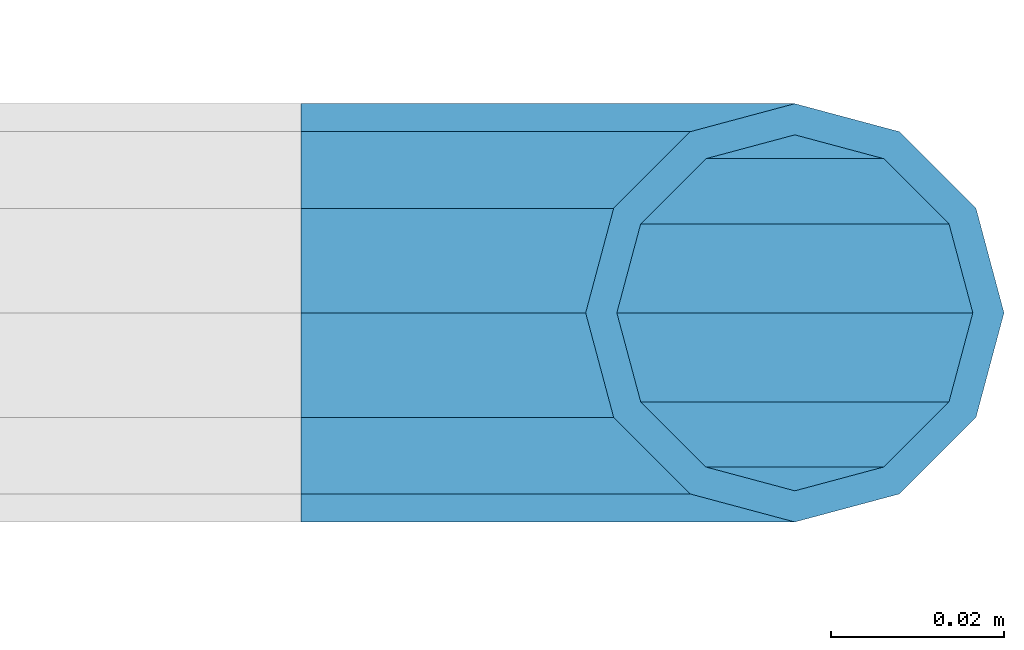
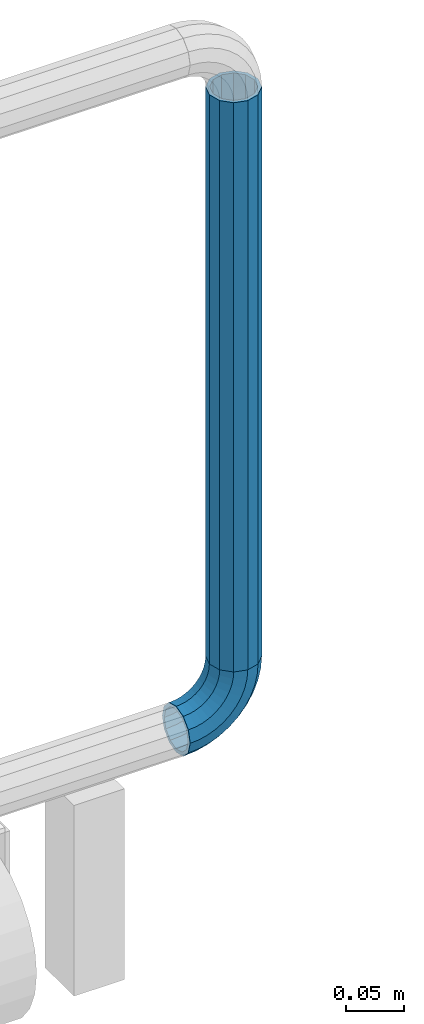
# One storey, part 151 of 208: 1 beam, 1 member.
"""IFC2X3 building model written with IfcOpenShell, lengths in millimetres."""

from ifc_helpers import new_model, si_unit, frame, origin_with_axes, place, context, subcontext, project, spatial, faceted_brep, material, type_object, element, save


model = new_model("IFC2X3")

# Units and contexts
model_context = context("Model", 3, precision=1e-05, world=origin_with_axes())
body_context = subcontext(model_context, "Body", "Model", "MODEL_VIEW")
ifc_project = project(units=[si_unit("LENGTHUNIT", "METRE", prefix="MILLI"), si_unit("AREAUNIT", "SQUARE_METRE"), si_unit("VOLUMEUNIT", "CUBIC_METRE"), si_unit("MASSUNIT", "GRAM", prefix="KILO"), si_unit("TIMEUNIT", "SECOND"), si_unit("PLANEANGLEUNIT", "RADIAN"), si_unit("SOLIDANGLEUNIT", "STERADIAN"), si_unit("THERMODYNAMICTEMPERATUREUNIT", "DEGREE_CELSIUS"), si_unit("LUMINOUSINTENSITYUNIT", "LUMEN")], contexts=[model_context])

# Site, building, storey
site_placement = place(None, origin_with_axes())
site = spatial("IfcSite", under=ifc_project, at=site_placement, CompositionType="ELEMENT")
building_placement = place(site_placement, origin_with_axes())
building = spatial("IfcBuilding", under=site, at=building_placement, Name="Standard", CompositionType="ELEMENT")
storey_placement = place(building_placement, origin_with_axes())
storey = spatial("IfcBuildingStorey", under=building, at=storey_placement, Name="Undefined", CompositionType="ELEMENT", Elevation=0.0)

# Member
ifc_material = material()
member_type = type_object("IfcMemberType", PredefinedType="NOTDEFINED")
member_placement = place(storey_placement, frame((-12120.0539827644, 5941.85399999618, 281.650006544463), z_axis=(0.0, -1.0, 0.0), x_axis=(-0.707106781186548, 0.0, -0.707106781186548)))
element("IfcMember", 1, at=member_placement, inside=storey, type_object=member_type, material=ifc_material, context=body_context, shape_type="Brep", body=[
    faceted_brep([(17.0766287656552, -17.0766287656552, 0.0), (14.7887943220539, -14.7887943220539, -12.0749999999998), (19.0945697419538, -11.1113146999724, -12.0749999999998), (20.9963409898282, -13.7288782624146, 0.0), (8.53831438282759, -8.53831438282759, -20.9145135013941), (13.8988340683954, -3.95999805533756, -20.9145135013941), (0.0, 0.0, -24.1500000000001), (6.80132714696265, 5.80888215173945, -24.1500000000001), (-8.53831438282759, 8.53831438282759, -20.9145135013941), (-0.296179774470147, 15.5777623588165, -20.9145135013941), (-14.7887943220521, 14.7887943220521, -12.0749999999998), (-5.49191544802852, 22.7290790034513, -12.0749999999998), (-17.0766287656552, 17.0766287656552, 0.0), (-7.39368669589931, 25.3466425658935, 0.0), (-14.7887943220521, 14.7887943220521, 12.0749999999998), (-5.49191544802852, 22.7290790034513, 12.0749999999998), (-8.53831438282759, 8.53831438282759, 20.9145135013941), (-0.296179774470147, 15.5777623588165, 20.9145135013941), (0.0, 0.0, 24.1500000000001), (6.80132714696265, 5.80888215173945, 24.1500000000001), (8.53831438282759, -8.53831438282759, 20.9145135013941), (13.8988340683954, -3.95999805533756, 20.9145135013941), (14.7887943220539, -14.7887943220539, 12.0749999999998), (19.0945697419538, -11.1113146999724, 12.0749999999998), (14.5310443533836, -14.5310443533836, 0.0), (12.5842535535485, -12.5842535535485, 10.2750000000001), (17.2620366843166, -8.58904933077247, 10.2750000000001), (18.8803140815726, -10.8164170826676, 0.0), (7.26552217669268, -7.26552217669268, 17.7968220477701), (12.8408206142685, -2.50376746546499, 17.7968220477701), (0.0, 0.0, 20.5500000000002), (6.80132714696265, 5.80888215173945, 20.5500000000002), (-7.26552217669087, 7.26552217669087, 17.7968220477701), (0.761833679658594, 14.1215317689421, 17.7968220477701), (-12.5842535535485, 12.5842535535485, 10.2750000000001), (-3.65938239039133, 20.2068136342514, 10.2750000000001), (-14.5310443533836, 14.5310443533836, 0.0), (-5.27765978764546, 22.4341813861447, 0.0), (-12.5842535535485, 12.5842535535485, -10.2750000000001), (-3.65938239039133, 20.2068136342514, -10.2750000000001), (-7.26552217669087, 7.26552217669087, -17.7968220477701), (0.761833679658594, 14.1215317689421, -17.7968220477701), (0.0, 0.0, -20.5500000000002), (6.80132714696265, 5.80888215173945, -20.5500000000002), (7.26552217669268, -7.26552217669268, -17.7968220477701), (12.8408206142685, -2.50376746546499, -17.7968220477701), (12.5842535535485, -12.5842535535485, -10.2750000000001), (17.2620366843166, -8.58904933077247, -10.2750000000001), (23.9226184787876, -8.15268262886457, -12.0749999999998), (25.3914986111904, -11.0355222080452, 0.0), (19.9095633268353, -0.27661842847192, -20.9145135013941), (14.4276280424801, 10.482285351105, -24.1500000000001), (8.94569275812501, 21.2411891306783, -20.9145135013941), (4.93263760617265, 29.117253331071, -12.0749999999998), (3.46375747377169, 32.0000929102534, 0.0), (4.93263760617265, 29.117253331071, 12.0749999999998), (8.94569275812501, 21.2411891306783, 20.9145135013941), (14.4276280424801, 10.482285351105, 24.1500000000001), (19.9095633268353, -0.27661842847192, 20.9145135013941), (23.9226184787876, -8.15268262886457, 12.0749999999998), (22.5072161777225, -5.3747992032786, 10.2750000000001), (23.7571328121267, -7.82789872096691, 0.0), (19.0923804273043, 1.32719331506814, 17.7968220477701), (14.4276280424801, 10.482285351105, 20.5500000000002), (9.76287565765597, 19.6373773871383, 17.7968220477701), (6.34803990723776, 26.3393699054886, 10.2750000000001), (5.0981232728318, 28.7924694231751, 0.0), (6.34803990723776, 26.3393699054886, -10.2750000000001), (9.76287565765597, 19.6373773871383, -17.7968220477701), (14.4276280424801, 10.482285351105, -20.5500000000002), (19.0923804273043, 1.32719331506814, -17.7968220477701), (22.5072161777225, -5.3747992032786, -10.2750000000001), (29.1540579492776, -5.98574944945176, -12.0749999999998), (30.1538782624175, -9.06287996733772, 0.0), (26.422498055339, 2.42112746692692, -20.9145135013941), (22.6911178482624, 13.9051349011897, -24.1500000000001), (18.9597376411857, 25.3891423354562, -20.9145135013941), (16.2281777472472, 33.7960192518349, -12.0749999999998), (15.2283574341091, 36.873149769719, 0.0), (16.2281777472472, 33.7960192518349, 12.0749999999998), (18.9597376411857, 25.3891423354562, 20.9145135013941), (22.6911178482624, 13.9051349011897, 24.1500000000001), (26.422498055339, 2.42112746692692, 20.9145135013941), (29.1540579492776, -5.98574944945176, 12.0749999999998), (28.1906383068908, -3.0206486766856, 10.2750000000001), (29.041417082668, -5.63907650867441, 0.0), (25.8662674654661, 4.13302919625858, 17.7968220477701), (22.6911178482624, 13.9051349011897, 20.5500000000002), (19.5159682310605, 23.6772406061227, 17.7968220477701), (17.1915973896339, 30.8309184790687, 10.2750000000001), (16.3408186138568, 33.4493463110575, 0.0), (17.1915973896339, 30.8309184790687, -10.2750000000001), (19.5159682310605, 23.6772406061227, -17.7968220477701), (22.6911178482624, 13.9051349011897, -20.5500000000002), (25.8662674654661, 4.13302919625858, -17.7968220477701), (28.1906383068908, -3.0206486766856, -10.2750000000001), (34.660072751507, -4.66387224825667, -12.0749999999998), (35.1662143510621, -7.85952453908249, 0.0), (33.2772681857005, 4.06681217360347, -20.9145135013941), (31.3883220203406, 15.9931488862876, -24.1500000000001), (29.4993758549808, 27.9194855989754, -20.9145135013941), (28.1165712891743, 36.6501700208355, -12.0749999999998), (27.6104296896192, 39.8458223116613, 0.0), (28.1165712891743, 36.6501700208355, 12.0749999999998), (29.4993758549808, 27.9194855989754, 20.9145135013941), (31.3883220203406, 15.9931488862876, 24.1500000000001), (33.2772681857005, 4.06681217360347, 20.9145135013941), (34.660072751507, -4.66387224825667, 12.0749999999998), (34.1723583568, -1.58456474993909, 10.2750000000001), (34.6030502769172, -4.30384651293934, 0.0), (32.995686148628, 5.84465118667504, 17.7968220477701), (31.3883220203406, 15.9931488862876, 20.5500000000002), (29.7809578920533, 26.1416465859038, 17.7968220477701), (28.6042856838831, 33.5708625225197, 10.2750000000001), (28.1735937637659, 36.29014428552, 0.0), (28.6042856838831, 33.5708625225197, -10.2750000000001), (29.7809578920533, 26.1416465859038, -17.7968220477701), (31.3883220203406, 15.9931488862876, -20.5500000000002), (32.995686148628, 5.84465118667504, -17.7968220477701), (34.1723583568, -1.58456474993909, -10.2750000000001), (40.3050865276346, -4.21960002902779, -12.0749999999998), (40.3050865276346, -7.45508652763237, 0.0), (40.3050865276327, 4.61991347236653, -20.9145135013941), (40.3050865276327, 16.6949134723673, -24.1500000000001), (40.3050865276346, 28.7699134723662, -20.9145135013941), (40.3050865276346, 37.6094269737623, -12.0749999999998), (40.3050865276346, 40.8449134723669, 0.0), (40.3050865276346, 37.6094269737623, 12.0749999999998), (40.3050865276346, 28.7699134723662, 20.9145135013941), (40.3050865276327, 16.6949134723673, 24.1500000000001), (40.3050865276327, 4.61991347236653, 20.9145135013941), (40.3050865276346, -4.21960002902779, 12.0749999999998), (40.3050865276327, -1.10190857540329, 10.2750000000001), (40.3050865276346, -3.85508652763383, 0.0), (40.3050865276346, 6.41991347236763, 17.7968220477701), (40.3050865276327, 16.6949134723673, 20.5500000000002), (40.3050865276346, 26.9699134723669, 17.7968220477701), (40.3050865276346, 34.491735520136, 10.2750000000001), (40.3050865276327, 37.2449134723665, 0.0), (40.3050865276346, 34.491735520136, -10.2750000000001), (40.3050865276346, 26.9699134723669, -17.7968220477701), (40.3050865276327, 16.6949134723673, -20.5500000000002), (40.3050865276346, 6.41991347236763, -17.7968220477701), (40.3050865276327, -1.10190857540329, -10.2750000000001), (45.9501003037603, -4.66387224825485, -12.0749999999998), (45.4439587042052, -7.8595245390843, 0.0), (47.3329048695668, 4.06681217360529, -20.9145135013941), (49.2218510349267, 15.9931488862894, -24.1500000000001), (51.1107972002883, 27.9194855989754, -20.9145135013941), (52.4936017660948, 36.6501700208355, -12.0749999999998), (52.9997433656481, 39.8458223116631, 0.0), (52.4936017660948, 36.6501700208355, 12.0749999999998), (51.1107972002883, 27.9194855989754, 20.9145135013941), (49.2218510349267, 15.9931488862894, 24.1500000000001), (47.3329048695668, 4.06681217360529, 20.9145135013941), (45.9501003037603, -4.66387224825485, 12.0749999999998), (46.4378146984691, -1.58456474993909, 10.2750000000001), (46.0071227783501, -4.30384651294116, 0.0), (47.6144869066393, 5.84465118667322, 17.7968220477701), (49.2218510349267, 15.9931488862894, 20.5500000000002), (50.8292151632158, 26.1416465859038, 17.7968220477701), (52.0058873713861, 33.5708625225197, 10.2750000000001), (52.4365792915032, 36.29014428552, 0.0), (52.0058873713861, 33.5708625225197, -10.2750000000001), (50.8292151632158, 26.1416465859038, -17.7968220477701), (49.2218510349267, 15.9931488862894, -20.5500000000002), (47.6144869066393, 5.84465118667322, -17.7968220477701), (46.4378146984691, -1.58456474993909, -10.2750000000001), (51.4561151059897, -5.98574944945358, -12.0749999999998), (50.4562947928516, -9.06287996733772, 0.0), (54.1876749999301, 2.42112746692692, -20.9145135013941), (57.9190552070068, 13.9051349011897, -24.1500000000001), (61.6504354140834, 25.3891423354562, -20.9145135013941), (64.3819953080219, 33.7960192518349, -12.0749999999998), (65.3818156211601, 36.873149769719, 0.0), (64.3819953080219, 33.7960192518349, 12.0749999999998), (61.6504354140834, 25.3891423354562, 20.9145135013941), (57.9190552070068, 13.9051349011897, 24.1500000000001), (54.1876749999301, 2.42112746692692, 20.9145135013941), (51.4561151059897, -5.98574944945358, 12.0749999999998), (52.4195347483783, -3.0206486766856, 10.2750000000001), (51.5687559726011, -5.63907650867441, 0.0), (54.743905589803, 4.13302919625858, 17.7968220477701), (57.9190552070068, 13.9051349011897, 20.5500000000002), (61.0942048242086, 23.6772406061227, 17.7968220477701), (63.4185756656334, 30.8309184790669, 10.2750000000001), (64.2693544414105, 33.4493463110557, 0.0), (63.4185756656334, 30.8309184790669, -10.2750000000001), (61.0942048242086, 23.6772406061227, -17.7968220477701), (57.9190552070068, 13.9051349011897, -20.5500000000002), (54.743905589803, 4.13302919625858, -17.7968220477701), (52.4195347483783, -3.0206486766856, -10.2750000000001), (56.6875545764815, -8.15268262886457, -12.0749999999998), (55.2186744440787, -11.0355222080452, 0.0), (60.7006097284338, -0.27661842847192, -20.9145135013941), (66.182545012789, 10.482285351105, -24.1500000000001), (71.6644802971441, 21.2411891306783, -20.9145135013941), (75.6775354490965, 29.117253331071, -12.0749999999998), (77.1464155814974, 32.0000929102534, 0.0), (75.6775354490965, 29.117253331071, 12.0749999999998), (71.6644802971441, 21.2411891306783, 20.9145135013941), (66.182545012789, 10.482285351105, 24.1500000000001), (60.7006097284338, -0.27661842847192, 20.9145135013941), (56.6875545764815, -8.15268262886457, 12.0749999999998), (58.1029568775466, -5.3747992032786, 10.2750000000001), (56.8530402431425, -7.82789872096691, 0.0), (61.5177926279648, 1.32719331506814, 17.7968220477701), (66.182545012789, 10.482285351105, 20.5500000000002), (70.8472973976113, 19.6373773871401, 17.7968220477701), (74.2621331480332, 26.3393699054868, 10.2750000000001), (75.5120497824355, 28.7924694231733, 0.0), (74.2621331480332, 26.3393699054868, -10.2750000000001), (70.8472973976113, 19.6373773871401, -17.7968220477701), (66.182545012789, 10.482285351105, -20.5500000000002), (61.5177926279648, 1.32719331506814, -17.7968220477701), (58.1029568775466, -5.3747992032786, -10.2750000000001), (61.5156033133135, -11.1113146999742, -12.0749999999998), (59.6138320654427, -13.7288782624164, 0.0), (66.7113389868737, -3.95999805533756, -20.9145135013941), (73.8088459083046, 5.80888215173763, -24.1500000000001), (80.9063528297374, 15.5777623588183, -20.9145135013941), (86.1020885032976, 22.7290790034513, -12.0749999999998), (88.0038597511684, 25.3466425658935, 0.0), (86.1020885032976, 22.7290790034513, 12.0749999999998), (80.9063528297374, 15.5777623588183, 20.9145135013941), (73.8088459083046, 5.80888215173763, 24.1500000000001), (66.7113389868737, -3.95999805533756, 20.9145135013941), (61.5156033133135, -11.1113146999742, 12.0749999999998), (63.3481363709525, -8.58904933077247, 10.2750000000001), (61.7298589736947, -10.8164170826658, 0.0), (67.7693524409988, -2.50376746546317, 17.7968220477701), (73.8088459083046, 5.80888215173763, 20.5500000000002), (79.8483393756105, 14.1215317689421, 17.7968220477701), (84.2695554456586, 20.2068136342532, 10.2750000000001), (85.8878328429146, 22.4341813861447, 0.0), (84.2695554456586, 20.2068136342532, -10.2750000000001), (79.8483393756105, 14.1215317689421, -17.7968220477701), (73.8088459083046, 5.80888215173763, -20.5500000000002), (67.7693524409988, -2.50376746546317, -17.7968220477701), (63.3481363709525, -8.58904933077247, -10.2750000000001), (65.8213787332152, -14.7887943220539, -12.0749999999998), (63.5335442896121, -17.0766287656534, 0.0), (72.0718586724379, -8.53831438282759, -20.9145135013941), (80.6101730552673, 1.81898940354586e-12, -24.1500000000001), (89.1484874380967, 8.53831438282759, -20.9145135013941), (95.3989673773231, 14.7887943220539, -12.0749999999998), (97.6868018209225, 17.0766287656534, 0.0), (95.3989673773231, 14.7887943220539, 12.0749999999998), (89.1484874380967, 8.53831438282759, 20.9145135013941), (80.6101730552673, 1.81898940354586e-12, 24.1500000000001), (72.0718586724379, -8.53831438282759, 20.9145135013941), (65.8213787332152, -14.7887943220539, 12.0749999999998), (68.0259195017188, -12.5842535535503, 10.2750000000001), (66.0791287018856, -14.5310443533836, 0.0), (73.3446508785764, -7.26552217669268, 17.7968220477701), (80.6101730552673, 1.81898940354586e-12, 20.5500000000002), (87.8756952319582, 7.26552217669268, 17.7968220477701), (93.1944266088158, 12.5842535535503, 10.2750000000001), (95.141217408649, 14.5310443533836, 0.0), (93.1944266088158, 12.5842535535503, -10.2750000000001), (87.8756952319582, 7.26552217669268, -17.7968220477701), (80.6101730552673, 1.81898940354586e-12, -20.5500000000002), (73.3446508785764, -7.26552217669268, -17.7968220477701), (68.0259195017188, -12.5842535535503, -10.2750000000001)], [[[0, 1, 2, 3]], [[1, 4, 5, 2]], [[4, 6, 7, 5]], [[6, 8, 9, 7]], [[8, 10, 11, 9]], [[10, 12, 13, 11]], [[12, 14, 15, 13]], [[14, 16, 17, 15]], [[16, 18, 19, 17]], [[18, 20, 21, 19]], [[20, 22, 23, 21]], [[22, 0, 3, 23]], [[24, 25, 26, 27]], [[25, 28, 29, 26]], [[28, 30, 31, 29]], [[30, 32, 33, 31]], [[32, 34, 35, 33]], [[34, 36, 37, 35]], [[36, 38, 39, 37]], [[38, 40, 41, 39]], [[40, 42, 43, 41]], [[42, 44, 45, 43]], [[44, 46, 47, 45]], [[46, 24, 27, 47]], [[22, 20, 18, 16, 14, 12, 10, 8, 6, 4, 1, 0], [46, 44, 42, 40, 38, 36, 34, 32, 30, 28, 25, 24]], [[3, 2, 48, 49]], [[2, 5, 50, 48]], [[5, 7, 51, 50]], [[7, 9, 52, 51]], [[9, 11, 53, 52]], [[11, 13, 54, 53]], [[13, 15, 55, 54]], [[15, 17, 56, 55]], [[17, 19, 57, 56]], [[19, 21, 58, 57]], [[21, 23, 59, 58]], [[23, 3, 49, 59]], [[27, 26, 60, 61]], [[26, 29, 62, 60]], [[29, 31, 63, 62]], [[31, 33, 64, 63]], [[33, 35, 65, 64]], [[35, 37, 66, 65]], [[37, 39, 67, 66]], [[39, 41, 68, 67]], [[41, 43, 69, 68]], [[43, 45, 70, 69]], [[45, 47, 71, 70]], [[47, 27, 61, 71]], [[49, 48, 72, 73]], [[48, 50, 74, 72]], [[50, 51, 75, 74]], [[51, 52, 76, 75]], [[52, 53, 77, 76]], [[53, 54, 78, 77]], [[54, 55, 79, 78]], [[55, 56, 80, 79]], [[56, 57, 81, 80]], [[57, 58, 82, 81]], [[58, 59, 83, 82]], [[59, 49, 73, 83]], [[61, 60, 84, 85]], [[60, 62, 86, 84]], [[62, 63, 87, 86]], [[63, 64, 88, 87]], [[64, 65, 89, 88]], [[65, 66, 90, 89]], [[66, 67, 91, 90]], [[67, 68, 92, 91]], [[68, 69, 93, 92]], [[69, 70, 94, 93]], [[70, 71, 95, 94]], [[71, 61, 85, 95]], [[73, 72, 96, 97]], [[72, 74, 98, 96]], [[74, 75, 99, 98]], [[75, 76, 100, 99]], [[76, 77, 101, 100]], [[77, 78, 102, 101]], [[78, 79, 103, 102]], [[79, 80, 104, 103]], [[80, 81, 105, 104]], [[81, 82, 106, 105]], [[82, 83, 107, 106]], [[83, 73, 97, 107]], [[85, 84, 108, 109]], [[84, 86, 110, 108]], [[86, 87, 111, 110]], [[87, 88, 112, 111]], [[88, 89, 113, 112]], [[89, 90, 114, 113]], [[90, 91, 115, 114]], [[91, 92, 116, 115]], [[92, 93, 117, 116]], [[93, 94, 118, 117]], [[94, 95, 119, 118]], [[95, 85, 109, 119]], [[97, 96, 120, 121]], [[96, 98, 122, 120]], [[98, 99, 123, 122]], [[99, 100, 124, 123]], [[100, 101, 125, 124]], [[101, 102, 126, 125]], [[102, 103, 127, 126]], [[103, 104, 128, 127]], [[104, 105, 129, 128]], [[105, 106, 130, 129]], [[106, 107, 131, 130]], [[107, 97, 121, 131]], [[109, 108, 132, 133]], [[108, 110, 134, 132]], [[110, 111, 135, 134]], [[111, 112, 136, 135]], [[112, 113, 137, 136]], [[113, 114, 138, 137]], [[114, 115, 139, 138]], [[115, 116, 140, 139]], [[116, 117, 141, 140]], [[117, 118, 142, 141]], [[118, 119, 143, 142]], [[119, 109, 133, 143]], [[121, 120, 144, 145]], [[120, 122, 146, 144]], [[122, 123, 147, 146]], [[123, 124, 148, 147]], [[124, 125, 149, 148]], [[125, 126, 150, 149]], [[126, 127, 151, 150]], [[127, 128, 152, 151]], [[128, 129, 153, 152]], [[129, 130, 154, 153]], [[130, 131, 155, 154]], [[131, 121, 145, 155]], [[133, 132, 156, 157]], [[132, 134, 158, 156]], [[134, 135, 159, 158]], [[135, 136, 160, 159]], [[136, 137, 161, 160]], [[137, 138, 162, 161]], [[138, 139, 163, 162]], [[139, 140, 164, 163]], [[140, 141, 165, 164]], [[141, 142, 166, 165]], [[142, 143, 167, 166]], [[143, 133, 157, 167]], [[145, 144, 168, 169]], [[144, 146, 170, 168]], [[146, 147, 171, 170]], [[147, 148, 172, 171]], [[148, 149, 173, 172]], [[149, 150, 174, 173]], [[150, 151, 175, 174]], [[151, 152, 176, 175]], [[152, 153, 177, 176]], [[153, 154, 178, 177]], [[154, 155, 179, 178]], [[155, 145, 169, 179]], [[157, 156, 180, 181]], [[156, 158, 182, 180]], [[158, 159, 183, 182]], [[159, 160, 184, 183]], [[160, 161, 185, 184]], [[161, 162, 186, 185]], [[162, 163, 187, 186]], [[163, 164, 188, 187]], [[164, 165, 189, 188]], [[165, 166, 190, 189]], [[166, 167, 191, 190]], [[167, 157, 181, 191]], [[169, 168, 192, 193]], [[168, 170, 194, 192]], [[170, 171, 195, 194]], [[171, 172, 196, 195]], [[172, 173, 197, 196]], [[173, 174, 198, 197]], [[174, 175, 199, 198]], [[175, 176, 200, 199]], [[176, 177, 201, 200]], [[177, 178, 202, 201]], [[178, 179, 203, 202]], [[179, 169, 193, 203]], [[181, 180, 204, 205]], [[180, 182, 206, 204]], [[182, 183, 207, 206]], [[183, 184, 208, 207]], [[184, 185, 209, 208]], [[185, 186, 210, 209]], [[186, 187, 211, 210]], [[187, 188, 212, 211]], [[188, 189, 213, 212]], [[189, 190, 214, 213]], [[190, 191, 215, 214]], [[191, 181, 205, 215]], [[193, 192, 216, 217]], [[192, 194, 218, 216]], [[194, 195, 219, 218]], [[195, 196, 220, 219]], [[196, 197, 221, 220]], [[197, 198, 222, 221]], [[198, 199, 223, 222]], [[199, 200, 224, 223]], [[200, 201, 225, 224]], [[201, 202, 226, 225]], [[202, 203, 227, 226]], [[203, 193, 217, 227]], [[205, 204, 228, 229]], [[204, 206, 230, 228]], [[206, 207, 231, 230]], [[207, 208, 232, 231]], [[208, 209, 233, 232]], [[209, 210, 234, 233]], [[210, 211, 235, 234]], [[211, 212, 236, 235]], [[212, 213, 237, 236]], [[213, 214, 238, 237]], [[214, 215, 239, 238]], [[215, 205, 229, 239]], [[217, 216, 240, 241]], [[216, 218, 242, 240]], [[218, 219, 243, 242]], [[219, 220, 244, 243]], [[220, 221, 245, 244]], [[221, 222, 246, 245]], [[222, 223, 247, 246]], [[223, 224, 248, 247]], [[224, 225, 249, 248]], [[225, 226, 250, 249]], [[226, 227, 251, 250]], [[227, 217, 241, 251]], [[229, 228, 252, 253]], [[228, 230, 254, 252]], [[230, 231, 255, 254]], [[231, 232, 256, 255]], [[232, 233, 257, 256]], [[233, 234, 258, 257]], [[234, 235, 259, 258]], [[235, 236, 260, 259]], [[236, 237, 261, 260]], [[237, 238, 262, 261]], [[238, 239, 263, 262]], [[239, 229, 253, 263]], [[242, 243, 244, 245, 246, 247, 248, 249, 250, 251, 241, 240], [254, 255, 256, 257, 258, 259, 260, 261, 262, 263, 253, 252]]]),
])

# Beam
beam_type = type_object("IfcBeamType", PredefinedType="NOTDEFINED")
beam_placement = place(storey_placement, frame((-12120.0539827644, 5941.85399999618, 878.350006544462), z_axis=(1.0, 0.0, 0.0), x_axis=(0.0, 0.0, -1.0)))
element("IfcBeam", 2, at=beam_placement, inside=storey, type_object=beam_type, material=ifc_material, context=body_context, shape_type="Brep", body=[
    faceted_brep([(0.0, -20.5500000000002, 0.0), (0.0, -17.7968220477701, 10.2749999999996), (596.700000000001, -17.7968220477701, 10.2749999999996), (596.700000000001, -20.5500000000002, 0.0), (0.0, -10.2750000000001, 17.7968220477705), (596.700000000001, -10.2750000000001, 17.7968220477705), (0.0, 0.0, 20.5500000000002), (596.700000000001, 0.0, 20.5499999999993), (0.0, 10.2750000000001, 17.7968220477705), (596.700000000001, 10.2750000000001, 17.7968220477705), (0.0, 17.7968220477701, 10.2749999999996), (596.700000000001, 17.7968220477701, 10.2749999999996), (0.0, 20.5500000000002, 0.0), (596.700000000001, 20.5500000000002, 0.0), (0.0, 17.7968220477701, -10.2749999999996), (596.700000000001, 17.7968220477701, -10.2749999999996), (0.0, 10.2750000000001, -17.7968220477705), (596.700000000001, 10.2750000000001, -17.7968220477705), (0.0, 0.0, -20.5500000000002), (596.700000000001, 0.0, -20.5499999999993), (0.0, -10.2750000000001, -17.7968220477705), (596.700000000001, -10.2750000000001, -17.7968220477705), (0.0, -17.7968220477701, -10.2749999999996), (596.700000000001, -17.7968220477701, -10.2749999999996), (0.0, -24.1500000000001, 0.0), (0.0, -20.9145135013941, -12.0750000000007), (596.700000000001, -20.9145135013941, -12.0750000000007), (596.700000000001, -24.1500000000001, 0.0), (0.0, -12.0749999999998, -20.914513501395), (596.700000000001, -12.0749999999998, -20.914513501395), (0.0, 0.0, -24.1500000000001), (596.700000000001, 0.0, -24.1499999999996), (0.0, 12.0749999999998, -20.914513501395), (596.700000000001, 12.0749999999998, -20.914513501395), (0.0, 20.9145135013941, -12.0750000000007), (596.700000000001, 20.9145135013941, -12.0750000000007), (0.0, 24.1500000000001, 0.0), (596.700000000001, 24.1500000000001, 0.0), (0.0, 20.9145135013941, 12.0750000000007), (596.700000000001, 20.9145135013941, 12.0750000000007), (0.0, 12.0749999999998, 20.914513501395), (596.700000000001, 12.0749999999998, 20.914513501395), (0.0, 0.0, 24.1500000000001), (596.700000000001, 0.0, 24.1499999999996), (0.0, -12.0749999999998, 20.914513501395), (596.700000000001, -12.0749999999998, 20.914513501395), (0.0, -20.9145135013941, 12.0750000000007), (596.700000000001, -20.9145135013941, 12.0750000000007)], [[[0, 1, 2, 3]], [[1, 4, 5, 2]], [[4, 6, 7, 5]], [[6, 8, 9, 7]], [[8, 10, 11, 9]], [[10, 12, 13, 11]], [[12, 14, 15, 13]], [[14, 16, 17, 15]], [[16, 18, 19, 17]], [[18, 20, 21, 19]], [[20, 22, 23, 21]], [[22, 0, 3, 23]], [[24, 25, 26, 27]], [[25, 28, 29, 26]], [[28, 30, 31, 29]], [[30, 32, 33, 31]], [[32, 34, 35, 33]], [[34, 36, 37, 35]], [[36, 38, 39, 37]], [[38, 40, 41, 39]], [[40, 42, 43, 41]], [[42, 44, 45, 43]], [[44, 46, 47, 45]], [[46, 24, 27, 47]], [[29, 31, 33, 35, 37, 39, 41, 43, 45, 47, 27, 26], [5, 7, 9, 11, 13, 15, 17, 19, 21, 23, 3, 2]], [[46, 44, 42, 40, 38, 36, 34, 32, 30, 28, 25, 24], [22, 20, 18, 16, 14, 12, 10, 8, 6, 4, 1, 0]]]),
])

save(model, "model.ifc")
